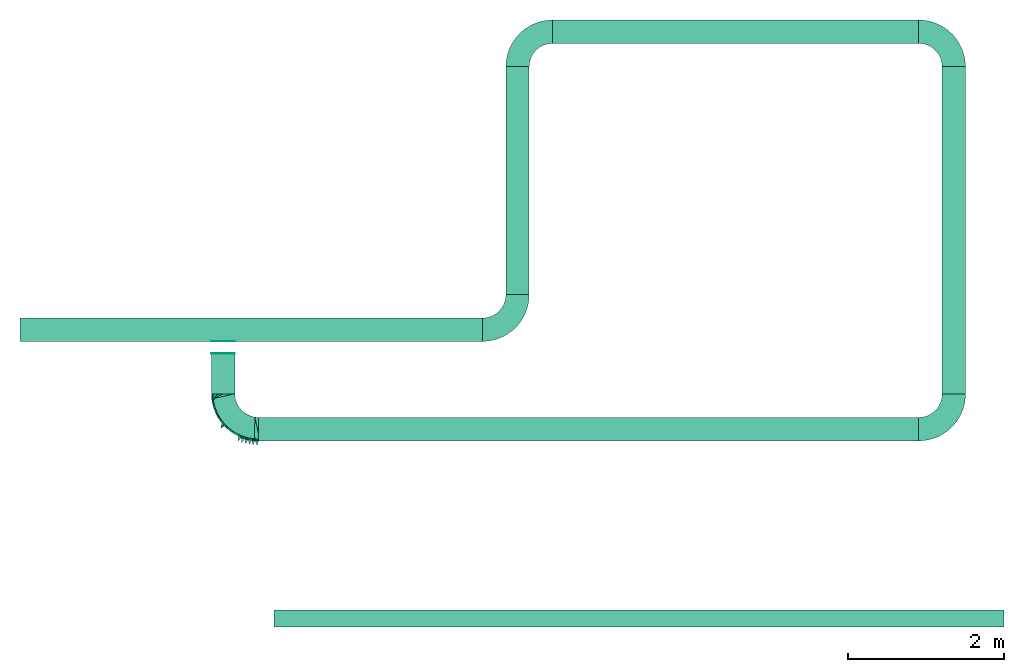
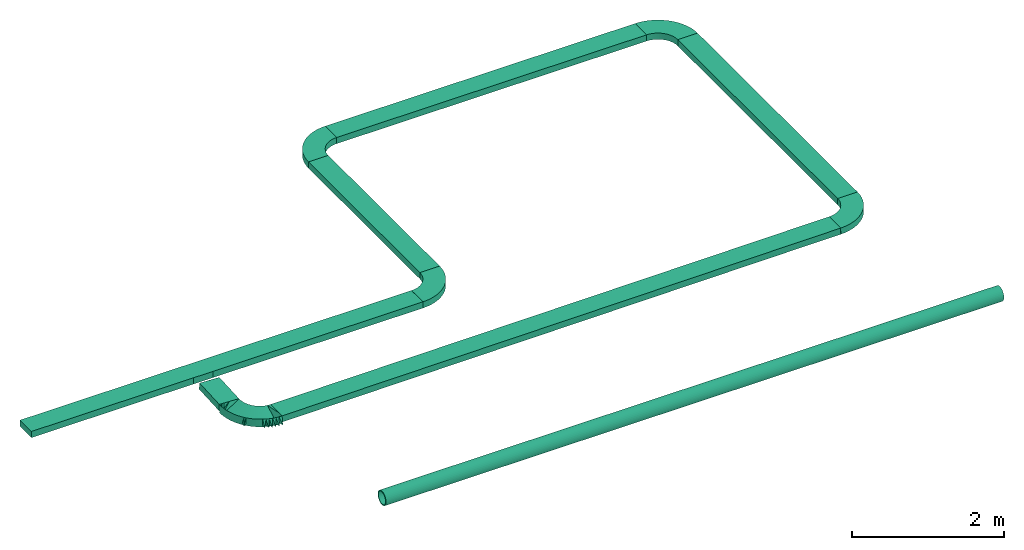
# Not in any storey: 7 flow segments, 6 flow fittings.
"""IFC4X3_ADD2 model written with IfcOpenShell, lengths in metres."""

import ifcopenshell
import ifcopenshell.guid

model = None  # the IFC model being written
_history = None  # IfcOwnerHistory: only IFC2X3 demands one
_inside = {}  # id of a spatial element -> (the spatial element, [elements in it])
_under = {}  # id of a project, library or spatial element -> (it, [spatial elements below it])
_declared = {}  # id of a project -> (the project, [libraries it declares])
_typed = {}  # id of a type object -> (the type object, [elements of that type])
_made_of = {}  # id of a material, layer set ... -> (it, [elements and type objects made of it])


def new_model(schema):
    """Start an empty IFC model of exactly this schema.

    Asked for "IFC4X3", IfcOpenShell would pick the latest addendum, in which some entities
    have other attributes; the version numbers below select the first issue.
    IFC2X3 requires an IfcOwnerHistory on every rooted entity: one is made here for all.
    """
    global model, _history
    if schema == "IFC4X3":
        model = ifcopenshell.file(schema_version=(4, 3, 0, 0))
    else:
        model = ifcopenshell.file(schema=schema)
    _inside.clear()
    _under.clear()
    _declared.clear()
    _typed.clear()
    _made_of.clear()
    _history = None
    if model.schema == "IFC2X3":
        org = make("IfcOrganization", Name="unknown")
        user = make(
            "IfcPersonAndOrganization",
            ThePerson=make("IfcPerson", FamilyName="unknown"),
            TheOrganization=org,
        )
        app = make(
            "IfcApplication",
            ApplicationDeveloper=org,
            Version="unknown",
            ApplicationFullName="unknown",
            ApplicationIdentifier="unknown",
        )
        _history = make(
            "IfcOwnerHistory",
            OwningUser=user,
            OwningApplication=app,
            ChangeAction="ADDED",
            CreationDate=0,
        )
    return model


def make(cls, **values):
    """One entity of the class cls with the attributes given. An attribute that is None is left unset."""
    return model.create_entity(
        cls, **{name: value for name, value in values.items() if value is not None}
    )


def entity(cls, *values):
    """Any entity or typed value of the class cls, its attributes in the order of the schema. None: left unset."""
    e = model.create_entity(cls)
    for i, value in enumerate(values):
        if value is not None:
            e[i] = value
    return e


def rooted(cls, **values):
    """An entity with a GlobalId (a new one), such as an element, a storey or a relation."""
    return make(cls, GlobalId=ifcopenshell.guid.new(), OwnerHistory=_history, **values)


def si_unit(unit_type, name, prefix=None):
    """IfcSIUnit, for example si_unit("LENGTHUNIT", "METRE", prefix="MILLI")."""
    return make("IfcSIUnit", UnitType=unit_type, Prefix=prefix, Name=name)


def assignment(units):
    """IfcUnitAssignment: the units of a project."""
    return None if units is None else make("IfcUnitAssignment", Units=units)


def point(xyz):
    """IfcCartesianPoint."""
    return None if xyz is None else make("IfcCartesianPoint", Coordinates=xyz)


def direction(xyz):
    """IfcDirection."""
    return None if xyz is None else make("IfcDirection", DirectionRatios=xyz)


def frame(location, z_axis=None, x_axis=None):
    """IfcAxis2Placement3D, a coordinate frame: its origin and axes. An axis left out is left unset."""
    return make(
        "IfcAxis2Placement3D",
        Location=point(location),
        Axis=direction(z_axis),
        RefDirection=direction(x_axis),
    )


def frame_2d(location, x_axis=None):
    """IfcAxis2Placement2D, a coordinate frame in the plane: its origin and x axis."""
    return make(
        "IfcAxis2Placement2D", Location=point(location), RefDirection=direction(x_axis)
    )


def origin_with_axes():
    """The frame at (0, 0, 0) with the z axis (0, 0, 1) and the x axis (1, 0, 0) written out."""
    return frame((0.0, 0.0, 0.0), z_axis=(0.0, 0.0, 1.0), x_axis=(1.0, 0.0, 0.0))


def origin_2d_with_axis():
    """The frame at (0, 0) in the plane with the x axis (1, 0) written out."""
    return frame_2d((0.0, 0.0), x_axis=(1.0, 0.0))


def place(relative_to, where):
    """IfcLocalPlacement: puts the frame where relative to a parent placement (None: the world)."""
    return make(
        "IfcLocalPlacement", PlacementRelTo=relative_to, RelativePlacement=where
    )


def context(
    kind, dimensions, precision=None, world=None, true_north=None, identifier=None
):
    """IfcGeometricRepresentationContext, for example the 3D "Model" context."""
    return make(
        "IfcGeometricRepresentationContext",
        ContextIdentifier=identifier,
        ContextType=kind,
        CoordinateSpaceDimension=dimensions,
        Precision=precision,
        WorldCoordinateSystem=world,
        TrueNorth=true_north,
    )


def subcontext(parent, identifier, kind, view, scale=None):
    """IfcGeometricRepresentationSubContext, for example "Body" below "Model"."""
    return make(
        "IfcGeometricRepresentationSubContext",
        ContextIdentifier=identifier,
        ContextType=kind,
        ParentContext=parent,
        TargetScale=scale,
        TargetView=view,
    )


def project(units=None, contexts=None):
    """IfcProject with its units and contexts."""
    return rooted(
        "IfcProject",
        Name="project",
        RepresentationContexts=contexts,
        UnitsInContext=assignment(units),
    )


def spatial(cls, under=None, at=None, **own):
    """A site, building, storey or space (cls), placed at a placement, below another one or the project."""
    s = rooted(cls, ObjectPlacement=at, **own)
    if under is not None:
        _under.setdefault(under.id(), (under, []))[1].append(s)
    return s


def polyline(points):
    """IfcPolyline through the points."""
    return make("IfcPolyline", Points=[point(p) for p in points])


def circle_curve(where, radius):
    """IfcCircle in the frame where."""
    return make("IfcCircle", Position=where, Radius=radius)


def trimmed(basis, trim1, trim2, sense, master):
    """IfcTrimmedCurve: the piece of a basis curve between two trims."""
    return make(
        "IfcTrimmedCurve",
        BasisCurve=basis,
        Trim1=trim1,
        Trim2=trim2,
        SenseAgreement=sense,
        MasterRepresentation=master,
    )


def segment(curve, same_sense, transition):
    """IfcCompositeCurveSegment."""
    return make(
        "IfcCompositeCurveSegment",
        Transition=transition,
        SameSense=same_sense,
        ParentCurve=curve,
    )


def composite_curve(segments, self_intersect=None):
    """IfcCompositeCurve: segments joined end to end."""
    return make("IfcCompositeCurve", Segments=segments, SelfIntersect=self_intersect)


def profile(cls, at=None, kind="AREA", **sizes):
    """A parametric profile (cls). Its sizes go by their IFC names, for example OverallWidth=200.0."""
    return make(cls, ProfileType=kind, Position=at, **sizes)


def rectangle(**sizes):
    """IfcRectangleProfileDef."""
    return profile("IfcRectangleProfileDef", **sizes)


def hollow_circle(**sizes):
    """IfcCircleHollowProfileDef."""
    return profile("IfcCircleHollowProfileDef", **sizes)


def outline(outer, holes=None, kind="AREA"):
    """IfcArbitraryClosedProfileDef: a profile drawn as a closed curve; with holes, ...WithVoids."""
    if holes is None:
        return make("IfcArbitraryClosedProfileDef", ProfileType=kind, OuterCurve=outer)
    return make(
        "IfcArbitraryProfileDefWithVoids",
        ProfileType=kind,
        OuterCurve=outer,
        InnerCurves=holes,
    )


def extrude(swept, where, along, depth):
    """IfcExtrudedAreaSolid: the profile swept, set in the frame where, extruded along a direction by depth."""
    return make(
        "IfcExtrudedAreaSolid",
        SweptArea=swept,
        Position=where,
        ExtrudedDirection=direction(along),
        Depth=depth,
    )


def faces_of(points, faces, orient=None, outer=None):
    """IfcFace entities. A face is a list of loops; a loop is a list of indices into points, from 0.

    orient and outer hold one flag for each loop. By default every Orientation is true, the
    first loop of a face is its IfcFaceOuterBound and the others are IfcFaceBound.
    """
    made = []
    for i, loops in enumerate(faces):
        bounds = []
        for j, loop in enumerate(loops):
            is_outer = j == 0 if outer is None else outer[i][j]
            bounds.append(
                make(
                    "IfcFaceOuterBound" if is_outer else "IfcFaceBound",
                    Bound=make("IfcPolyLoop", Polygon=[points[k] for k in loop]),
                    Orientation=True if orient is None else orient[i][j],
                )
            )
        made.append(make("IfcFace", Bounds=bounds))
    return made


def faceted_brep(points, faces, orient=None, outer=None, voids=None):
    """IfcFacetedBrep: a solid bounded by flat faces; with voids (closed shells), ...WithVoids."""
    shared = [point(p) for p in points]
    hull = make("IfcClosedShell", CfsFaces=faces_of(shared, faces, orient, outer))
    if voids is None:
        return make("IfcFacetedBrep", Outer=hull)
    return make(
        "IfcFacetedBrepWithVoids",
        Outer=hull,
        Voids=[
            make(cls, CfsFaces=faces_of(shared, fs, o, b)) for cls, fs, o, b in voids
        ],
    )


def shape(context_of_items, identifier, shape_type, items):
    """IfcShapeRepresentation: the items that make up one representation, for example the "Body"."""
    return make(
        "IfcShapeRepresentation",
        ContextOfItems=context_of_items,
        RepresentationIdentifier=identifier,
        RepresentationType=shape_type,
        Items=items,
    )


def material(Name=None, Category=None):
    """IfcMaterial."""
    return make("IfcMaterial", Name=Name, Category=Category)


def made_of(thing, what):
    """Note that an element or type object is made of a material, layer set ...; save() writes the relation."""
    if what is not None:
        _made_of.setdefault(what.id(), (what, []))[1].append(thing)
    return thing


def element(
    cls,
    number,
    at=None,
    inside=None,
    cuts=None,
    type_object=None,
    material=None,
    context=None,
    identifier="Body",
    shape_type=None,
    held_by="IfcProductDefinitionShape",
    body=None,
    shapes=None,
    **own,
):
    """One element of the class cls, such as IfcWall. Its Tag is "e" and its number.

    at: its placement. inside: the storey or other place that contains it. cuts: it is an
    opening in that element (IfcRelVoidsElement). A single representation is given by context,
    identifier, shape_type and body (its items); several are given by shapes. held_by: the class
    of the entity that holds the representations. save() writes the other relations.
    """
    e = rooted(cls, Tag="e%d" % number, ObjectPlacement=at, **own)
    if body is not None:
        shapes = [shape(context, identifier, shape_type, body)]
    if shapes is not None:
        e.Representation = make(held_by, Representations=shapes)
    if inside is not None:
        _inside.setdefault(inside.id(), (inside, []))[1].append(e)
    if cuts is not None:
        rooted(
            "IfcRelVoidsElement", RelatingBuildingElement=cuts, RelatedOpeningElement=e
        )
    if type_object is not None:
        _typed.setdefault(type_object.id(), (type_object, []))[1].append(e)
    return made_of(e, material)


def aggregate(whole, parts):
    """IfcRelAggregates: a whole, such as a stair, and the parts it consists of."""
    return rooted("IfcRelAggregates", RelatingObject=whole, RelatedObjects=parts)


def save(model, path):
    """Write the relations noted so far, then the file.

    IfcRelAggregates (storeys below a building ...), IfcRelContainedInSpatialStructure (elements
    in a storey), IfcRelDefinesByType, IfcRelAssociatesMaterial and IfcRelDeclares: one each for
    every whole, place, type object, material and project.
    """
    for whole, parts in _under.values():
        aggregate(whole, parts)
    for where, things in _inside.values():
        rooted(
            "IfcRelContainedInSpatialStructure",
            RelatedElements=things,
            RelatingStructure=where,
        )
    for kind, things in _typed.values():
        rooted("IfcRelDefinesByType", RelatedObjects=things, RelatingType=kind)
    for what, things in _made_of.values():
        rooted("IfcRelAssociatesMaterial", RelatedObjects=things, RelatingMaterial=what)
    for by, libraries in _declared.values():
        rooted("IfcRelDeclares", RelatingContext=by, RelatedDefinitions=libraries)
    model.write(path)


model = new_model("IFC4X3_ADD2")

# Units and contexts
model_context = context("Model", 3, precision=1e-05, world=origin_with_axes(), true_north=direction((0.0, 1.0)))
body_context = subcontext(model_context, "Body", "Model", "MODEL_VIEW")
ifc_project = project(units=[si_unit("LENGTHUNIT", "METRE"), si_unit("AREAUNIT", "SQUARE_METRE"), si_unit("VOLUMEUNIT", "CUBIC_METRE"), si_unit("PLANEANGLEUNIT", "RADIAN"), si_unit("TIMEUNIT", "SECOND"), si_unit("MASSUNIT", "GRAM")], contexts=[model_context])

# Site
site_placement = place(None, origin_with_axes())
site = spatial("IfcSite", under=ifc_project, at=site_placement, CompositionType="ELEMENT")

# Flow segments
ifc_material = material(Name="Steel")
flow_segment_1_placement = place(site_placement, frame((-0.03733732820984059, -0.04742806947473, 0.0), z_axis=(1.0, 0.0, 0.0), x_axis=(0.0, 1.0, 0.0)))
element("IfcFlowSegment", 1, at=flow_segment_1_placement, inside=site, material=ifc_material, context=body_context, shape_type="SweptSolid", body=[
    extrude(hollow_circle(Radius=0.1095376, WallThickness=0.0150876, at=origin_2d_with_axis()), origin_with_axes(), (0.0, 0.0, 1.0), 9.36796894331219),
])
flow_segment_2_placement = place(site_placement, frame((-3.298311987711156, 3.659739348651863, 0.0), z_axis=(1.0, 0.0, 0.0), x_axis=(0.0, 1.0, 0.0)))
element("IfcFlowSegment", 2, at=flow_segment_2_placement, inside=site, material=ifc_material, context=body_context, shape_type="SweptSolid", body=[
    extrude(rectangle(XDim=0.3, YDim=0.1, at=origin_2d_with_axis()), origin_with_axes(), (0.0, 0.0, 1.0), 5.93550280223562),
])
flow_segment_3_placement = place(site_placement, frame((3.087190814524464, 4.109739348651862, 0.0), z_axis=(0.0, 1.0, 0.0), x_axis=(-1.0, 0.0, 0.0)))
element("IfcFlowSegment", 3, at=flow_segment_3_placement, inside=site, material=ifc_material, context=body_context, shape_type="SweptSolid", body=[
    extrude(rectangle(XDim=0.3, YDim=0.1, at=origin_2d_with_axis()), origin_with_axes(), (0.0, 0.0, 1.0), 2.924905613511732),
])

# Flow fitting
flow_fitting_1_placement = place(site_placement, frame((2.637190814524464, 4.109739348651862, -0.05), z_axis=(0.0, 0.0, 1.0), x_axis=(0.0, -1.0, 0.0)))
element("IfcFlowFitting", 4, at=flow_fitting_1_placement, inside=site, material=ifc_material, context=body_context, shape_type="SweptSolid", body=[
    extrude(outline(composite_curve([segment(polyline([(0.0, 0.2999999999999994), (0.0, 0.5999999999999992)]), True, "CONTINUOUS"), segment(trimmed(circle_curve(origin_2d_with_axis(), 0.5999999999999992), [point((0.0, 0.5999999999999992))], [point((0.5999999999999992, 0.0))], False, "CARTESIAN"), True, "CONTINUOUS"), segment(polyline([(0.5999999999999992, 0.0), (0.2999999999999994, 0.0)]), True, "CONTINUOUS"), segment(trimmed(circle_curve(origin_2d_with_axis(), 0.2999999999999994), [point((0.2999999999999994, 0.0))], [point((0.0, 0.2999999999999994))], True, "CARTESIAN"), True, "CONTINUOUS")], self_intersect=False)), origin_with_axes(), (0.0, 0.0, 1.0), 0.1),
])

# Flow segment
flow_segment_4_placement = place(site_placement, frame((3.537190814524463, 7.484644962163594, 0.0), z_axis=(1.0, 0.0, 0.0), x_axis=(0.0, 1.0, 0.0)))
element("IfcFlowSegment", 5, at=flow_segment_4_placement, inside=site, material=ifc_material, context=body_context, shape_type="SweptSolid", body=[
    extrude(rectangle(XDim=0.3, YDim=0.1, at=origin_2d_with_axis()), origin_with_axes(), (0.0, 0.0, 1.0), 4.699204206741831),
])

# Flow fitting
flow_fitting_2_placement = place(site_placement, frame((2.937190814524464, 7.034644962163594, -0.05), z_axis=(0.0, 0.0, 1.0), x_axis=(1.0, 0.0, 0.0)))
element("IfcFlowFitting", 6, at=flow_fitting_2_placement, inside=site, material=ifc_material, context=body_context, shape_type="SweptSolid", body=[
    extrude(outline(composite_curve([segment(polyline([(0.0, 0.5999999999999992), (0.0, 0.2999999999999994)]), True, "CONTINUOUS"), segment(trimmed(circle_curve(origin_2d_with_axis(), 0.2999999999999998), [point((0.0, 0.2999999999999994))], [point((-0.2999999999999998, 0.0))], True, "CARTESIAN"), True, "CONTINUOUS"), segment(polyline([(-0.2999999999999998, 0.0), (-0.5999999999999996, 0.0)]), True, "CONTINUOUS"), segment(trimmed(circle_curve(origin_2d_with_axis(), 0.5999999999999996), [point((-0.5999999999999996, 0.0))], [point((0.0, 0.5999999999999992))], False, "CARTESIAN"), True, "CONTINUOUS")], self_intersect=False)), frame((0.5999999999999996, 0.0, 0.0), z_axis=(0.0, 0.0, 1.0), x_axis=(1.0, 0.0, 0.0)), (0.0, 0.0, 1.0), 0.1),
])

# Flow segment
flow_segment_5_placement = place(site_placement, frame((8.686395021266295, 7.034644962163592, 0.0), z_axis=(0.0, -1.0, 0.0), x_axis=(1.0, 0.0, 0.0)))
element("IfcFlowSegment", 7, at=flow_segment_5_placement, inside=site, material=ifc_material, context=body_context, shape_type="SweptSolid", body=[
    extrude(rectangle(XDim=0.3, YDim=0.1, at=origin_2d_with_axis()), origin_with_axes(), (0.0, 0.0, 1.0), 4.199968552752506),
])

# Flow fitting
flow_fitting_3_placement = place(site_placement, frame((8.236395021266294, 7.034644962163592, -0.05), z_axis=(0.0, 0.0, 1.0), x_axis=(1.0, 0.0, 0.0)))
element("IfcFlowFitting", 8, at=flow_fitting_3_placement, inside=site, material=ifc_material, context=body_context, shape_type="SweptSolid", body=[
    extrude(outline(composite_curve([segment(polyline([(0.5999999999999992, 0.0), (0.2999999999999994, 0.0)]), True, "CONTINUOUS"), segment(trimmed(circle_curve(origin_2d_with_axis(), 0.3000000000000007), [point((0.2999999999999994, 0.0))], [point((0.0, 0.2999999999999994))], True, "CARTESIAN"), True, "CONTINUOUS"), segment(polyline([(0.0, 0.2999999999999994), (0.0, 0.5999999999999992)]), True, "CONTINUOUS"), segment(trimmed(circle_curve(origin_2d_with_axis(), 0.6000000000000014), [point((0.0, 0.5999999999999992))], [point((0.5999999999999992, 0.0))], False, "CARTESIAN"), True, "CONTINUOUS")], self_intersect=False)), origin_with_axes(), (0.0, 0.0, 1.0), 0.1),
])

# Flow segment
flow_segment_6_placement = place(site_placement, frame((8.235608072051177, 2.383883052830796, -0.002403487934136557), z_axis=(-0.9999857864693953, 0.0, -0.005331684460413036), x_axis=(2.842685918547404e-05, -0.9999857864693951, -0.005331608678353339)))
element("IfcFlowSegment", 9, at=flow_segment_6_placement, inside=site, material=ifc_material, context=body_context, shape_type="SweptSolid", body=[
    extrude(rectangle(XDim=0.3, YDim=0.1, at=origin_2d_with_axis()), origin_with_axes(), (0.0, 0.0, 1.0), 8.470192088433073),
])

# Flow fitting
flow_fitting_4_placement = place(site_placement, frame((8.23533722758838, 2.834676409411086, -0.05320180789293023), z_axis=(0.0, 0.0, 1.0), x_axis=(0.0, -1.0, 0.0)))
cartesian_point_1 = entity("IfcCartesianPoint", [0.6005246403276794, 0.0005416889255904778, 0.0])
vertex_point_1 = entity("IfcVertexPoint", cartesian_point_1)
cartesian_point_2 = entity("IfcCartesianPoint", [0.3005289043868595, 0.0005331608678353916, 0.001599482603505828])
vertex_point_2 = entity("IfcVertexPoint", cartesian_point_2)
edge_curve_1 = entity("IfcEdgeCurve", vertex_point_1, vertex_point_2, entity("IfcPolyline", [cartesian_point_1, cartesian_point_2]), True)
cartesian_point_3 = entity("IfcCartesianPoint", [0.0, 0.3010577936779146, 0.003201807892930224])
vertex_point_3 = entity("IfcVertexPoint", cartesian_point_3)
edge_curve_2 = entity("IfcEdgeCurve", vertex_point_3, vertex_point_2, entity("IfcRationalBSplineCurveWithKnots", 2, [entity("IfcCartesianPoint", [0.0, 0.3010577936779147, 0.003201807892930204]), entity("IfcCartesianPoint", [0.3005289043868594, 0.3010577936779147, 0.003201807892930207]), entity("IfcCartesianPoint", [0.3005289043868594, 0.0005331608678354583, 0.001599482603505832])], "UNSPECIFIED", False, "UNKNOWN", [3, 3], [0.0, 1.570796326794897], "UNSPECIFIED", [1.0, 0.7071067811865476, 1.0]), True)
cartesian_point_4 = entity("IfcCartesianPoint", [0.0, 0.6010577936779153, 0.003201807892930224])
vertex_point_4 = entity("IfcVertexPoint", cartesian_point_4)
edge_curve_3 = entity("IfcEdgeCurve", vertex_point_4, vertex_point_3, entity("IfcPolyline", [cartesian_point_4, cartesian_point_3]), True)
edge_curve_4 = entity("IfcEdgeCurve", vertex_point_4, vertex_point_1, entity("IfcRationalBSplineCurveWithKnots", 2, [entity("IfcCartesianPoint", [0.0, 0.6010577936779153, 0.003201807892930212]), entity("IfcCartesianPoint", [0.600524640327679, 0.6010577936779153, 0.003201807892930219]), entity("IfcCartesianPoint", [0.6005246403276792, 0.000541688925590611, 0.0])], "UNSPECIFIED", False, "UNKNOWN", [3, 3], [0.0, 1.570796326794897], "UNSPECIFIED", [1.0, 0.7071067811865476, 1.0]), True)
cartesian_point_5 = entity("IfcCartesianPoint", [0.0, 0.0005374248967129347, 0.000799741301752914])
ifc_direction_1 = entity("IfcDirection", [-1.0, 0.0, 0.0])
ifc_direction_2 = entity("IfcDirection", [0.0, 0.9999857864693952, 0.005331684460413043])
ifc_direction_3 = entity("IfcDirection", [0.0, 0.005331684460413043, -0.9999857864693952])
cartesian_point_6 = entity("IfcCartesianPoint", [0.301062072832901, 0.0, 0.1015966399175873])
vertex_point_5 = entity("IfcVertexPoint", cartesian_point_6)
edge_curve_5 = entity("IfcEdgeCurve", vertex_point_2, vertex_point_5, entity("IfcPolyline", [cartesian_point_2, cartesian_point_6]), True)
cartesian_point_7 = entity("IfcCartesianPoint", [0.0, 0.3010577936779146, 0.1032018078929302])
vertex_point_6 = entity("IfcVertexPoint", cartesian_point_7)
edge_curve_6 = entity("IfcEdgeCurve", vertex_point_6, vertex_point_5, entity("IfcRationalBSplineCurveWithKnots", 2, [entity("IfcCartesianPoint", [0.0, 0.3010577936779147, 0.1032018078929303]), entity("IfcCartesianPoint", [0.3010620728329008, 0.3010577936779147, 0.1032018078929303]), entity("IfcCartesianPoint", [0.3010620728329008, 0.0, 0.1015966399175873])], "UNSPECIFIED", False, "UNKNOWN", [3, 3], [0.0, 1.570796326794897], "UNSPECIFIED", [1.0, 0.7071067811865476, 1.0]), True)
edge_curve_7 = entity("IfcEdgeCurve", vertex_point_3, vertex_point_6, entity("IfcPolyline", [cartesian_point_3, cartesian_point_7]), True)
cartesian_point_8 = entity("IfcCartesianPoint", [0.0, 0.0002665804339176958, 0.05159806126054658])
cartesian_point_9 = entity("IfcCartesianPoint", [0.6010578087737208, 8.528057755086138e-06, 0.0999971573140815])
vertex_point_7 = entity("IfcVertexPoint", cartesian_point_9)
edge_curve_8 = entity("IfcEdgeCurve", vertex_point_5, vertex_point_7, entity("IfcPolyline", [cartesian_point_6, cartesian_point_9]), True)
cartesian_point_10 = entity("IfcCartesianPoint", [0.0, 0.6010577936779153, 0.1032018078929302])
vertex_point_8 = entity("IfcVertexPoint", cartesian_point_10)
edge_curve_9 = entity("IfcEdgeCurve", vertex_point_8, vertex_point_7, entity("IfcRationalBSplineCurveWithKnots", 2, [entity("IfcCartesianPoint", [0.0, 0.6010577936779155, 0.1032018078929303]), entity("IfcCartesianPoint", [0.6010578087737205, 0.6010577936779155, 0.1032018078929303]), entity("IfcCartesianPoint", [0.6010578087737206, 8.528057755219558e-06, 0.0999971573140815])], "UNSPECIFIED", False, "UNKNOWN", [3, 3], [0.0, 1.570796326794897], "UNSPECIFIED", [1.0, 0.7071067811865476, 1.0]), True)
edge_curve_10 = entity("IfcEdgeCurve", vertex_point_6, vertex_point_8, entity("IfcPolyline", [cartesian_point_7, cartesian_point_10]), True)
cartesian_point_11 = entity("IfcCartesianPoint", [0.0, 4.264028877543069e-06, 0.1007968986158344])
edge_curve_11 = entity("IfcEdgeCurve", vertex_point_7, vertex_point_1, entity("IfcPolyline", [cartesian_point_9, cartesian_point_1]), True)
edge_curve_12 = entity("IfcEdgeCurve", vertex_point_8, vertex_point_4, entity("IfcPolyline", [cartesian_point_10, cartesian_point_4]), True)
cartesian_point_12 = entity("IfcCartesianPoint", [0.0, 0.000275108491672782, 0.04999857865704074])
element("IfcFlowFitting", 10, at=flow_fitting_4_placement, inside=site, material=ifc_material, context=body_context, shape_type="AdvancedBrep", body=[
    entity("IfcAdvancedBrep", entity("IfcClosedShell", [entity("IfcAdvancedFace", [entity("IfcFaceOuterBound", entity("IfcEdgeLoop", [entity("IfcOrientedEdge", None, None, edge_curve_1, True), entity("IfcOrientedEdge", None, None, edge_curve_2, False), entity("IfcOrientedEdge", None, None, edge_curve_3, False), entity("IfcOrientedEdge", None, None, edge_curve_4, True)]), True)], entity("IfcSurfaceOfRevolution", entity("IfcArbitraryOpenProfileDef", "CURVE", None, entity("IfcPolyline", [entity("IfcCartesianPoint", [0.0, -0.002402100733509589]), entity("IfcCartesianPoint", [0.4505267723572693, 0.0])])), entity("IfcAxis2Placement3D", cartesian_point_5, ifc_direction_1, ifc_direction_2), entity("IfcAxis1Placement", cartesian_point_5, ifc_direction_3)), False), entity("IfcAdvancedFace", [entity("IfcFaceOuterBound", entity("IfcEdgeLoop", [entity("IfcOrientedEdge", None, None, edge_curve_5, True), entity("IfcOrientedEdge", None, None, edge_curve_6, False), entity("IfcOrientedEdge", None, None, edge_curve_7, False), entity("IfcOrientedEdge", None, None, edge_curve_2, True)]), True)], entity("IfcSurfaceOfRevolution", entity("IfcArbitraryOpenProfileDef", "CURVE", None, entity("IfcPolyline", [entity("IfcCartesianPoint", [0.0, 56.41579419737356]), entity("IfcCartesianPoint", [0.3007954886098801, 0.0])])), entity("IfcAxis2Placement3D", cartesian_point_8, ifc_direction_1, ifc_direction_2), entity("IfcAxis1Placement", cartesian_point_8, ifc_direction_3)), False), entity("IfcAdvancedFace", [entity("IfcFaceOuterBound", entity("IfcEdgeLoop", [entity("IfcOrientedEdge", None, None, edge_curve_8, True), entity("IfcOrientedEdge", None, None, edge_curve_9, False), entity("IfcOrientedEdge", None, None, edge_curve_10, False), entity("IfcOrientedEdge", None, None, edge_curve_6, True)]), True)], entity("IfcSurfaceOfRevolution", entity("IfcArbitraryOpenProfileDef", "CURVE", None, entity("IfcPolyline", [entity("IfcCartesianPoint", [0.4510599408033107, 0.0]), entity("IfcCartesianPoint", [0.0, -0.002404943459833308])])), entity("IfcAxis2Placement3D", cartesian_point_11, ifc_direction_1, ifc_direction_2), entity("IfcAxis1Placement", cartesian_point_11, ifc_direction_3)), True), entity("IfcAdvancedFace", [entity("IfcFaceOuterBound", entity("IfcEdgeLoop", [entity("IfcOrientedEdge", None, None, edge_curve_11, True), entity("IfcOrientedEdge", None, None, edge_curve_4, False), entity("IfcOrientedEdge", None, None, edge_curve_12, False), entity("IfcOrientedEdge", None, None, edge_curve_9, True)]), True)], entity("IfcSurfaceOfRevolution", entity("IfcArbitraryOpenProfileDef", "CURVE", None, entity("IfcPolyline", [entity("IfcCartesianPoint", [0.6007912245506998, 0.0]), entity("IfcCartesianPoint", [0.0, 112.681590526777])])), entity("IfcAxis2Placement3D", cartesian_point_12, ifc_direction_1, ifc_direction_2), entity("IfcAxis1Placement", cartesian_point_12, ifc_direction_3)), True), entity("IfcAdvancedFace", [entity("IfcFaceOuterBound", entity("IfcEdgeLoop", [entity("IfcOrientedEdge", None, None, edge_curve_1, False), entity("IfcOrientedEdge", None, None, edge_curve_11, False), entity("IfcOrientedEdge", None, None, edge_curve_8, False), entity("IfcOrientedEdge", None, None, edge_curve_5, False)]), True)], entity("IfcPlane", entity("IfcAxis2Placement3D", entity("IfcCartesianPoint", [0.4507933565802915, 0.0002708444627952389, 0.05079831995879366]), ifc_direction_2, ifc_direction_1)), False), entity("IfcAdvancedFace", [entity("IfcFaceOuterBound", entity("IfcEdgeLoop", [entity("IfcOrientedEdge", None, None, edge_curve_12, True), entity("IfcOrientedEdge", None, None, edge_curve_3, True), entity("IfcOrientedEdge", None, None, edge_curve_7, True), entity("IfcOrientedEdge", None, None, edge_curve_10, True)]), True)], entity("IfcPlane", entity("IfcAxis2Placement3D", entity("IfcCartesianPoint", [0.0, 0.451057793677915, 0.05320180789293023]), ifc_direction_1, entity("IfcDirection", [0.0, -1.0, 0.0]))), True)])),
])

# Flow segment
flow_segment_7_placement = place(site_placement, frame((-0.691505323366005, 2.84010173624608, -0.02480533731528497), z_axis=(-0.0002939983055543381, 0.9984785373759271, 0.05514094635228925), x_axis=(-0.9990093542954859, -0.00274701618370268, 0.0444158072334928)))
element("IfcFlowSegment", 11, at=flow_segment_7_placement, inside=site, material=ifc_material, context=body_context, shape_type="SweptSolid", body=[
    extrude(rectangle(XDim=0.3, YDim=0.1, at=origin_2d_with_axis()), origin_with_axes(), (0.0, 0.0, 1.0), 0.5172295839353636),
])

# Flow fittings
flow_fitting_5_placement = place(site_placement, frame((-0.8435817348609254, 2.843258932094338, -0.09851886955135782), z_axis=(0.0, 0.0, 1.0), x_axis=(2.842726322539062e-05, -0.9999999995959454, 0.0)))
cartesian_point_13 = entity("IfcCartesianPoint", [0.000815585124213758, 0.0, 0.03050139299510045])
vertex_point_9 = entity("IfcVertexPoint", cartesian_point_13)
cartesian_point_14 = entity("IfcCartesianPoint", [0.0, 0.2997028295945946, 0.01717665082505242])
vertex_point_10 = entity("IfcVertexPoint", cartesian_point_14)
edge_curve_13 = entity("IfcEdgeCurve", vertex_point_9, vertex_point_10, entity("IfcPolyline", [cartesian_point_13, cartesian_point_14]), True)
cartesian_point_15 = entity("IfcCartesianPoint", [0.3091287499629947, 0.60937163878042, 0.001756152727321422])
vertex_point_11 = entity("IfcVertexPoint", cartesian_point_15)
edge_curve_14 = entity("IfcEdgeCurve", vertex_point_11, vertex_point_10, entity("IfcRationalBSplineCurveWithKnots", 2, [entity("IfcCartesianPoint", [0.309128749962995, 0.60937163878042, 0.001756152727321405]), entity("IfcCartesianPoint", [0.3091199492638647, 0.2997850613833809, 0.0001055113213520795]), entity("IfcCartesianPoint", [0.0, 0.2997028295945947, 0.01717665082505242])], "UNSPECIFIED", False, "UNKNOWN", [3, 3], [0.0, 1.570796326794893], "UNSPECIFIED", [1.0, 0.7071067811865488, 1.0]), True)
cartesian_point_16 = entity("IfcCartesianPoint", [0.6091244860250282, 0.6093716387804204, 0.0001566701238154417])
vertex_point_12 = entity("IfcVertexPoint", cartesian_point_16)
edge_curve_15 = entity("IfcEdgeCurve", vertex_point_12, vertex_point_11, entity("IfcPolyline", [cartesian_point_16, cartesian_point_15]), True)
edge_curve_16 = entity("IfcEdgeCurve", vertex_point_12, vertex_point_9, entity("IfcRationalBSplineCurveWithKnots", 2, [entity("IfcCartesianPoint", [0.6091244860250281, 0.6093716387804204, 0.0001566701238154347]), entity("IfcCartesianPoint", [0.6091071678570619, 0.0001618171362623988, -0.003091490584519782]), entity("IfcCartesianPoint", [0.0008155851242136823, 0.0, 0.03050139299510046])], "UNSPECIFIED", False, "UNKNOWN", [3, 3], [0.0, 1.570796326794894], "UNSPECIFIED", [1.0, 0.7071067811865481, 1.0]), True)
cartesian_point_17 = entity("IfcCartesianPoint", [0.0004208519956541146, 0.6092496143178969, 0.02628842296722879])
ifc_direction_4 = entity("IfcDirection", [2.842685917357356e-05, 0.9999857860653462, 0.005331684460413037])
ifc_direction_5 = entity("IfcDirection", [0.9984785453300543, 0.0002656142932272445, -0.05514094635228924])
ifc_direction_6 = entity("IfcDirection", [-0.05514157875408067, 0.005325140028108718, -0.9984643454706775])
cartesian_point_18 = entity("IfcCartesianPoint", [0.005507452802109736, 0.3041526433660703, 0.1169256714770454])
vertex_point_13 = entity("IfcVertexPoint", cartesian_point_18)
edge_curve_17 = entity("IfcEdgeCurve", vertex_point_10, vertex_point_13, entity("IfcPolyline", [cartesian_point_14, cartesian_point_18]), True)
cartesian_point_19 = entity("IfcCartesianPoint", [0.309661903252517, 0.6088384627562807, 0.1017533100414029])
vertex_point_14 = entity("IfcVertexPoint", cartesian_point_19)
edge_curve_18 = entity("IfcEdgeCurve", vertex_point_14, vertex_point_13, entity("IfcRationalBSplineCurveWithKnots", 2, [entity("IfcCartesianPoint", [0.3096619032525171, 0.6088384627562807, 0.1017533100414029]), entity("IfcCartesianPoint", [0.3096532441685342, 0.3042335519342014, 0.1001292296872353]), entity("IfcCartesianPoint", [0.005507452802109768, 0.3041526433660702, 0.1169256714770454])], "UNSPECIFIED", False, "UNKNOWN", [3, 3], [0.0, 1.570796326794895], "UNSPECIFIED", [1.0, 0.7071067811865478, 1.0]), True)
edge_curve_19 = entity("IfcEdgeCurve", vertex_point_11, vertex_point_14, entity("IfcPolyline", [cartesian_point_15, cartesian_point_19]), True)
cartesian_point_20 = entity("IfcCartesianPoint", [0.002762456292610516, 0.6090234805898924, 0.06868852203111744])
cartesian_point_21 = entity("IfcCartesianPoint", [0.006323037926323494, 0.004449813771475353, 0.1302504136470934])
vertex_point_15 = entity("IfcVertexPoint", cartesian_point_21)
edge_curve_20 = entity("IfcEdgeCurve", vertex_point_13, vertex_point_15, entity("IfcPolyline", [cartesian_point_18, cartesian_point_21]), True)
cartesian_point_22 = entity("IfcCartesianPoint", [0.6096576393145501, 0.6088384627562807, 0.1001538274378969])
vertex_point_16 = entity("IfcVertexPoint", cartesian_point_22)
edge_curve_21 = entity("IfcEdgeCurve", vertex_point_16, vertex_point_15, entity("IfcRationalBSplineCurveWithKnots", 2, [entity("IfcCartesianPoint", [0.6096576393145504, 0.6088384627562807, 0.1001538274378969]), entity("IfcCartesianPoint", [0.6096404627617312, 0.004610307687082482, 0.09693222778136343]), entity("IfcCartesianPoint", [0.006323037926323747, 0.00444981377147502, 0.1302504136470934])], "UNSPECIFIED", False, "UNKNOWN", [3, 3], [0.0, 1.570796326794895], "UNSPECIFIED", [1.0, 0.7071067811865479, 1.0]), True)
edge_curve_22 = entity("IfcEdgeCurve", vertex_point_14, vertex_point_16, entity("IfcPolyline", [cartesian_point_19, cartesian_point_22]), True)
cartesian_point_23 = entity("IfcCartesianPoint", [0.00592816318261713, 0.6087177615144118, 0.12601088256742])
edge_curve_23 = entity("IfcEdgeCurve", vertex_point_15, vertex_point_9, entity("IfcPolyline", [cartesian_point_21, cartesian_point_13]), True)
edge_curve_24 = entity("IfcEdgeCurve", vertex_point_16, vertex_point_12, entity("IfcPolyline", [cartesian_point_22, cartesian_point_16]), True)
cartesian_point_24 = entity("IfcCartesianPoint", [0.003586558885660285, 0.6089438952424164, 0.08361078350353136])
element("IfcFlowFitting", 12, at=flow_fitting_5_placement, inside=site, material=ifc_material, context=body_context, shape_type="AdvancedBrep", body=[
    entity("IfcAdvancedBrep", entity("IfcClosedShell", [entity("IfcAdvancedFace", [entity("IfcFaceOuterBound", entity("IfcEdgeLoop", [entity("IfcOrientedEdge", None, None, edge_curve_13, True), entity("IfcOrientedEdge", None, None, edge_curve_14, False), entity("IfcOrientedEdge", None, None, edge_curve_15, False), entity("IfcOrientedEdge", None, None, edge_curve_16, True)]), True)], entity("IfcSurfaceOfRevolution", entity("IfcArbitraryOpenProfileDef", "CURVE", None, entity("IfcPolyline", [entity("IfcCartesianPoint", [0.4594047294694039, 0.0]), entity("IfcCartesianPoint", [0.0, 0.02291478944760161])])), entity("IfcAxis2Placement3D", cartesian_point_17, ifc_direction_4, ifc_direction_5), entity("IfcAxis1Placement", cartesian_point_17, ifc_direction_6)), True), entity("IfcAdvancedFace", [entity("IfcFaceOuterBound", entity("IfcEdgeLoop", [entity("IfcOrientedEdge", None, None, edge_curve_17, True), entity("IfcOrientedEdge", None, None, edge_curve_18, False), entity("IfcOrientedEdge", None, None, edge_curve_19, False), entity("IfcOrientedEdge", None, None, edge_curve_14, True)]), True)], entity("IfcSurfaceOfRevolution", entity("IfcArbitraryOpenProfileDef", "CURVE", None, entity("IfcPolyline", [entity("IfcCartesianPoint", [0.0, -6.15686401633575]), entity("IfcCartesianPoint", [0.3071001092104442, 0.0])])), entity("IfcAxis2Placement3D", cartesian_point_20, ifc_direction_4, ifc_direction_5), entity("IfcAxis1Placement", cartesian_point_20, ifc_direction_6)), False), entity("IfcAdvancedFace", [entity("IfcFaceOuterBound", entity("IfcEdgeLoop", [entity("IfcOrientedEdge", None, None, edge_curve_20, True), entity("IfcOrientedEdge", None, None, edge_curve_21, False), entity("IfcOrientedEdge", None, None, edge_curve_22, False), entity("IfcOrientedEdge", None, None, edge_curve_18, True)]), True)], entity("IfcSurfaceOfRevolution", entity("IfcArbitraryOpenProfileDef", "CURVE", None, entity("IfcPolyline", [entity("IfcCartesianPoint", [0.0, 0.02266630384016455]), entity("IfcCartesianPoint", [0.454422992084354, 0.0])])), entity("IfcAxis2Placement3D", cartesian_point_23, ifc_direction_4, ifc_direction_5), entity("IfcAxis1Placement", cartesian_point_23, ifc_direction_6)), False), entity("IfcAdvancedFace", [entity("IfcFaceOuterBound", entity("IfcEdgeLoop", [entity("IfcOrientedEdge", None, None, edge_curve_23, True), entity("IfcOrientedEdge", None, None, edge_curve_16, False), entity("IfcOrientedEdge", None, None, edge_curve_24, False), entity("IfcOrientedEdge", None, None, edge_curve_21, True)]), True)], entity("IfcSurfaceOfRevolution", entity("IfcArbitraryOpenProfileDef", "CURVE", None, entity("IfcPolyline", [entity("IfcCartesianPoint", [0.6067276123433137, 0.0]), entity("IfcCartesianPoint", [0.0, -12.16391428110509])])), entity("IfcAxis2Placement3D", cartesian_point_24, ifc_direction_4, ifc_direction_5), entity("IfcAxis1Placement", cartesian_point_24, ifc_direction_6)), True), entity("IfcAdvancedFace", [entity("IfcFaceOuterBound", entity("IfcEdgeLoop", [entity("IfcOrientedEdge", None, None, edge_curve_13, False), entity("IfcOrientedEdge", None, None, edge_curve_23, False), entity("IfcOrientedEdge", None, None, edge_curve_20, False), entity("IfcOrientedEdge", None, None, edge_curve_17, False)]), True)], entity("IfcPlane", entity("IfcAxis2Placement3D", entity("IfcCartesianPoint", [0.003161518963161747, 0.1520763216830346, 0.07371353223607299]), ifc_direction_5, entity("IfcDirection", [-0.0002660190197106629, 0.99999996461694, 0.0]))), False), entity("IfcAdvancedFace", [entity("IfcFaceOuterBound", entity("IfcEdgeLoop", [entity("IfcOrientedEdge", None, None, edge_curve_24, True), entity("IfcOrientedEdge", None, None, edge_curve_15, True), entity("IfcOrientedEdge", None, None, edge_curve_19, True), entity("IfcOrientedEdge", None, None, edge_curve_22, True)]), True)], entity("IfcPlane", entity("IfcAxis2Placement3D", entity("IfcCartesianPoint", [0.459393194638773, 0.6091050507683509, 0.05095499008260919]), ifc_direction_4, entity("IfcDirection", [-0.9999999995959455, 2.842726322449221e-05, 0.0]))), True)])),
])
flow_fitting_6_placement = place(site_placement, frame((-0.843733776297332, 3.353378659121936, -0.05282168998670862), z_axis=(0.0, 0.0, 1.0), x_axis=(1.0, 0.0, 0.0)))
element("IfcFlowFitting", 13, at=flow_fitting_6_placement, inside=site, material=ifc_material, context=body_context, shape_type="Brep", body=[
    faceted_brep([(0.002076388310066957, 0.1563606895299263, 0.00282168998670862), (0.002076388310066957, 0.1563606895299263, 0.1028216899867086), (0.3020763883100668, 0.1563606895299263, 0.1028216899867086), (0.3020763883100668, 0.1563606895299263, 0.00282168998670862), (0.004449970331488307, 0.0, 0.1130737628220406), (0.0, 0.005507326303856974, 0.01332474217004774), (0.2997028062886455, 0.006331431158967948, 0.0), (0.3041527766201338, 0.0008241048551109742, 0.0997490206519928)], [[[0, 1, 2, 3]], [[4, 5, 6, 7]]]),
])

save(model, "model.ifc")
